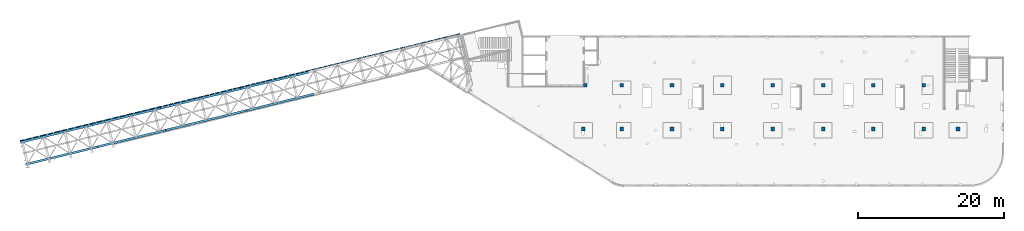
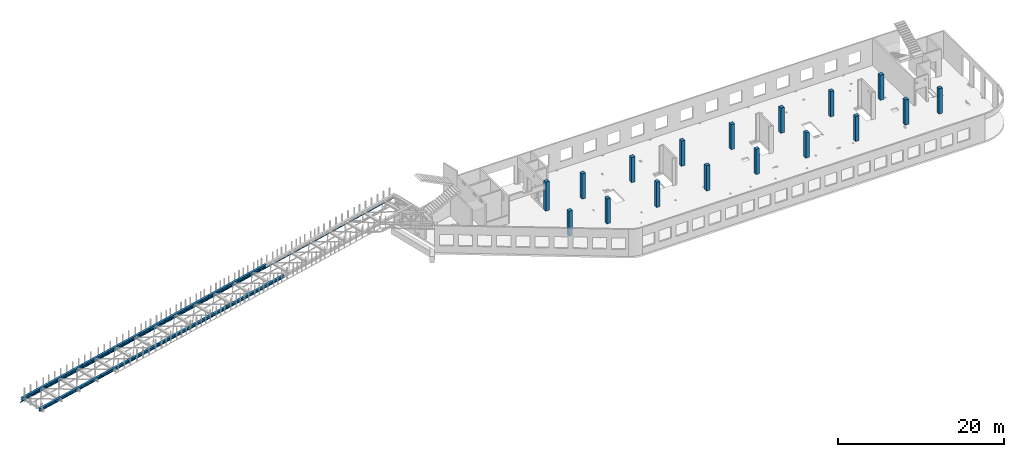
# One storey, part 12 of 66: 17 columns, 9 beams.
"""IFC4 building model written with IfcOpenShell, lengths in millimetres."""

from ifc_helpers import new_model, entity, si_unit, converted_unit, derived_unit, direction, frame, origin, place, context, subcontext, project, spatial, indexed_curve, outline, extrude, source, transform, mapped, material, type_object, type_shapes, element, save


model = new_model("IFC4")

# Units and contexts
model_context = context("Model", 3, precision=0.01, world=origin(), true_north=direction((6.12303176911189e-17, 1.0)))
plan_context = context("Plan", 3, precision=0.01, world=origin(), true_north=direction((6.12303176911189e-17, 1.0)))
body_context = subcontext(model_context, "Body", "Model", "MODEL_VIEW")
ifc_project = project(units=[si_unit("LENGTHUNIT", "METRE", prefix="MILLI"), si_unit("AREAUNIT", "SQUARE_METRE"), si_unit("VOLUMEUNIT", "CUBIC_METRE"), converted_unit("PLANEANGLEUNIT", "DEGREE", entity("IfcRatioMeasure", 0.0174532925199433), si_unit("PLANEANGLEUNIT", "RADIAN"), dimensions=[0, 0, 0, 0, 0, 0, 0]), si_unit("MASSUNIT", "GRAM", prefix="KILO"), derived_unit("MASSDENSITYUNIT", [(si_unit("MASSUNIT", "GRAM", prefix="KILO"), 1), (si_unit("LENGTHUNIT", "METRE"), -3)]), derived_unit("MOMENTOFINERTIAUNIT", [(si_unit("LENGTHUNIT", "METRE"), 4)]), si_unit("TIMEUNIT", "SECOND"), si_unit("FREQUENCYUNIT", "HERTZ"), si_unit("THERMODYNAMICTEMPERATUREUNIT", "DEGREE_CELSIUS"), derived_unit("THERMALTRANSMITTANCEUNIT", [(si_unit("MASSUNIT", "GRAM", prefix="KILO"), 1), (si_unit("THERMODYNAMICTEMPERATUREUNIT", "KELVIN"), -1), (si_unit("TIMEUNIT", "SECOND"), -3)]), derived_unit("VOLUMETRICFLOWRATEUNIT", [(si_unit("LENGTHUNIT", "METRE"), 3), (si_unit("TIMEUNIT", "SECOND"), -1)]), derived_unit("MASSFLOWRATEUNIT", [(si_unit("MASSUNIT", "GRAM", prefix="KILO"), 1), (si_unit("TIMEUNIT", "SECOND"), -1)]), derived_unit("ROTATIONALFREQUENCYUNIT", [(si_unit("TIMEUNIT", "SECOND"), -1)]), si_unit("ELECTRICCURRENTUNIT", "AMPERE"), si_unit("ELECTRICVOLTAGEUNIT", "VOLT"), si_unit("POWERUNIT", "WATT"), si_unit("FORCEUNIT", "NEWTON", prefix="KILO"), si_unit("ILLUMINANCEUNIT", "LUX"), si_unit("LUMINOUSFLUXUNIT", "LUMEN"), si_unit("LUMINOUSINTENSITYUNIT", "CANDELA"), derived_unit("USERDEFINED", [(si_unit("MASSUNIT", "GRAM", prefix="KILO"), -1), (si_unit("LENGTHUNIT", "METRE"), -2), (si_unit("TIMEUNIT", "SECOND"), 3), (si_unit("LUMINOUSFLUXUNIT", "LUMEN"), 1)]), derived_unit("LINEARVELOCITYUNIT", [(si_unit("LENGTHUNIT", "METRE"), 1), (si_unit("TIMEUNIT", "SECOND"), -1)]), si_unit("PRESSUREUNIT", "PASCAL"), derived_unit("USERDEFINED", [(si_unit("LENGTHUNIT", "METRE"), -2), (si_unit("MASSUNIT", "GRAM", prefix="KILO"), 1), (si_unit("TIMEUNIT", "SECOND"), -2)]), derived_unit("LINEARFORCEUNIT", [(si_unit("MASSUNIT", "GRAM", prefix="KILO"), 1), (si_unit("LENGTHUNIT", "METRE"), 1), (si_unit("TIMEUNIT", "SECOND"), -2), (si_unit("LENGTHUNIT", "METRE"), -1)]), derived_unit("PLANARFORCEUNIT", [(si_unit("MASSUNIT", "GRAM", prefix="KILO"), 1), (si_unit("LENGTHUNIT", "METRE"), 1), (si_unit("TIMEUNIT", "SECOND"), -2), (si_unit("LENGTHUNIT", "METRE"), -2)])], contexts=[model_context, plan_context])

# Site, building, storey
site_placement = place(None, origin())
site = spatial("IfcSite", under=ifc_project, at=site_placement, CompositionType="ELEMENT")
building_placement = place(site_placement, origin())
building = spatial("IfcBuilding", under=site, at=building_placement, CompositionType="ELEMENT")
storey_placement = place(building_placement, frame((0.0, 0.0, 19800.0)))
storey = spatial("IfcBuildingStorey", under=building, at=storey_placement, Name="06", CompositionType="ELEMENT", Elevation=19800.0)

# Columns
ifc_material_1 = material()
column_type_1 = type_object("IfcColumnType", PredefinedType="COLUMN", material=ifc_material_1)
shared_shape_1 = source(origin(), body_context, "Body", "SweptSolid", [
    extrude(outline(indexed_curve([(-249.999999999999, -249.999999999999), (250.000000000001, -249.999999999999), (250.000000000001, 249.999999999999), (-249.999999999999, 249.999999999999), (-249.999999999999, -249.999999999999)], self_intersect=False)), frame((15900.0, 7700.0, 19650.0), z_axis=(0.0, 0.0, 1.0), x_axis=(0.0, -1.0, 0.0)), (0.0, 0.0, 1.0), 3700.0),
])
type_shapes(column_type_1, [shared_shape_1])
placement_1 = place(storey_placement, frame((0.0, 0.0, -19800.0)))
element("IfcColumn", 1, at=placement_1, inside=storey, type_object=column_type_1, PredefinedType="COLUMN", context=body_context, shape_type="MappedRepresentation", body=[
    mapped(shared_shape_1, transform((0.0, 0.0, 0.0), scale=1.0)),
])
column_type_2 = type_object("IfcColumnType", PredefinedType="COLUMN", material=ifc_material_1)
shared_shape_2 = source(origin(), body_context, "Body", "SweptSolid", [
    extrude(outline(indexed_curve([(-249.999999999999, -249.999999999999), (250.000000000001, -249.999999999999), (250.000000000001, 249.999999999999), (-249.999999999999, 249.999999999999), (-249.999999999999, -249.999999999999)], self_intersect=False)), frame((21170.0, 7700.0, 19650.0), z_axis=(0.0, 0.0, 1.0), x_axis=(0.0, -1.0, 0.0)), (0.0, 0.0, 1.0), 3700.0),
])
type_shapes(column_type_2, [shared_shape_2])
element("IfcColumn", 2, at=placement_1, inside=storey, type_object=column_type_2, PredefinedType="COLUMN", context=body_context, shape_type="MappedRepresentation", body=[
    mapped(shared_shape_2, transform((0.0, 0.0, 0.0), scale=1.0)),
])
column_type_3 = type_object("IfcColumnType", PredefinedType="COLUMN", material=ifc_material_1)
shared_shape_3 = source(origin(), body_context, "Body", "SweptSolid", [
    extrude(outline(indexed_curve([(-249.999999999999, -249.999999999999), (250.000000000001, -249.999999999999), (249.999999999999, 249.999999999999), (-250.000000000001, 249.999999999999), (-249.999999999999, -249.999999999999)], self_intersect=False)), frame((28070.0, 7700.0, 19650.0), z_axis=(0.0, 0.0, 1.0), x_axis=(0.0, -1.0, 0.0)), (0.0, 0.0, 1.0), 3700.0),
])
type_shapes(column_type_3, [shared_shape_3])
element("IfcColumn", 3, at=placement_1, inside=storey, type_object=column_type_3, PredefinedType="COLUMN", context=body_context, shape_type="MappedRepresentation", body=[
    mapped(shared_shape_3, transform((0.0, 0.0, 0.0), scale=1.0)),
])
column_type_4 = type_object("IfcColumnType", PredefinedType="COLUMN", material=ifc_material_1)
shared_shape_4 = source(origin(), body_context, "Body", "SweptSolid", [
    extrude(outline(indexed_curve([(-249.999999999999, -250.000000000004), (250.000000000001, -250.000000000004), (250.000000000001, 249.999999999995), (-249.999999999999, 249.999999999995), (-249.999999999999, -250.000000000004)], self_intersect=False)), frame((34970.0, 7700.0, 19650.0), z_axis=(0.0, 0.0, 1.0), x_axis=(0.0, -1.0, 0.0)), (0.0, 0.0, 1.0), 3700.0),
])
type_shapes(column_type_4, [shared_shape_4])
element("IfcColumn", 4, at=placement_1, inside=storey, type_object=column_type_4, PredefinedType="COLUMN", context=body_context, shape_type="MappedRepresentation", body=[
    mapped(shared_shape_4, transform((0.0, 0.0, 0.0), scale=1.0)),
])
column_type_5 = type_object("IfcColumnType", PredefinedType="COLUMN", material=ifc_material_1)
shared_shape_5 = source(origin(), body_context, "Body", "SweptSolid", [
    extrude(outline(indexed_curve([(-249.999999999999, -250.000000000004), (250.000000000001, -250.000000000004), (249.999999999999, 249.999999999995), (-250.000000000001, 250.000000000004), (-249.999999999999, -250.000000000004)], self_intersect=False)), frame((41870.0, 7700.0, 19650.0), z_axis=(0.0, 0.0, 1.0), x_axis=(0.0, -1.0, 0.0)), (0.0, 0.0, 1.0), 3700.0),
])
type_shapes(column_type_5, [shared_shape_5])
element("IfcColumn", 5, at=placement_1, inside=storey, type_object=column_type_5, PredefinedType="COLUMN", context=body_context, shape_type="MappedRepresentation", body=[
    mapped(shared_shape_5, transform((0.0, 0.0, 0.0), scale=1.0)),
])
column_type_6 = type_object("IfcColumnType", PredefinedType="COLUMN", material=ifc_material_1)
shared_shape_6 = source(origin(), body_context, "Body", "SweptSolid", [
    extrude(outline(indexed_curve([(-249.999999999999, -250.000000000004), (250.000000000001, -250.000000000004), (250.000000000001, 249.999999999995), (-249.999999999999, 250.000000000004), (-249.999999999999, -250.000000000004)], self_intersect=False)), frame((48770.0, 7700.0, 19650.0), z_axis=(0.0, 0.0, 1.0), x_axis=(0.0, -1.0, 0.0)), (0.0, 0.0, 1.0), 3700.0),
])
type_shapes(column_type_6, [shared_shape_6])
element("IfcColumn", 6, at=placement_1, inside=storey, type_object=column_type_6, PredefinedType="COLUMN", context=body_context, shape_type="MappedRepresentation", body=[
    mapped(shared_shape_6, transform((0.0, 0.0, 0.0), scale=1.0)),
])
column_type_7 = type_object("IfcColumnType", PredefinedType="COLUMN", material=ifc_material_1)
shared_shape_7 = source(origin(), body_context, "Body", "SweptSolid", [
    extrude(outline(indexed_curve([(-249.999999999999, -250.000000000004), (250.000000000001, -250.000000000004), (249.999999999999, 249.999999999995), (-250.000000000001, 250.000000000004), (-249.999999999999, -250.000000000004)], self_intersect=False)), frame((55670.0, 7700.0, 19650.0), z_axis=(0.0, 0.0, 1.0), x_axis=(0.0, -1.0, 0.0)), (0.0, 0.0, 1.0), 3700.0),
])
type_shapes(column_type_7, [shared_shape_7])
element("IfcColumn", 7, at=placement_1, inside=storey, type_object=column_type_7, PredefinedType="COLUMN", context=body_context, shape_type="MappedRepresentation", body=[
    mapped(shared_shape_7, transform((0.0, 0.0, 0.0), scale=1.0)),
])
column_type_8 = type_object("IfcColumnType", PredefinedType="COLUMN", material=ifc_material_1)
shared_shape_8 = source(origin(), body_context, "Body", "SweptSolid", [
    extrude(outline(indexed_curve([(-249.999999999999, -250.000000000004), (250.000000000001, -250.000000000004), (250.000000000001, 249.999999999995), (-249.999999999999, 250.000000000004), (-249.999999999999, -250.000000000004)], self_intersect=False)), frame((62570.0, 7700.0, 19650.0), z_axis=(0.0, 0.0, 1.0), x_axis=(0.0, -1.0, 0.0)), (0.0, 0.0, 1.0), 3700.0),
])
type_shapes(column_type_8, [shared_shape_8])
element("IfcColumn", 8, at=placement_1, inside=storey, type_object=column_type_8, PredefinedType="COLUMN", context=body_context, shape_type="MappedRepresentation", body=[
    mapped(shared_shape_8, transform((0.0, 0.0, 0.0), scale=1.0)),
])
column_type_9 = type_object("IfcColumnType", PredefinedType="COLUMN", material=ifc_material_1)
shared_shape_9 = source(origin(), body_context, "Body", "SweptSolid", [
    extrude(outline(indexed_curve([(-249.999999999999, -250.000000000004), (250.000000000001, -250.000000000004), (250.000000000001, 249.999999999995), (-249.999999999999, 250.000000000004), (-249.999999999999, -250.000000000004)], self_intersect=False)), frame((67270.0, 7700.0, 19650.0), z_axis=(0.0, 0.0, 1.0), x_axis=(0.0, -1.0, 0.0)), (0.0, 0.0, 1.0), 3700.0),
])
type_shapes(column_type_9, [shared_shape_9])
element("IfcColumn", 9, at=placement_1, inside=storey, type_object=column_type_9, PredefinedType="COLUMN", context=body_context, shape_type="MappedRepresentation", body=[
    mapped(shared_shape_9, transform((0.0, 0.0, 0.0), scale=1.0)),
])
column_type_10 = type_object("IfcColumnType", PredefinedType="COLUMN", material=ifc_material_1)
shared_shape_10 = source(origin(), body_context, "Body", "SweptSolid", [
    extrude(outline(indexed_curve([(-249.999999999999, -249.999999999999), (249.999999999999, -249.999999999999), (249.999999999999, 249.999999999999), (-249.999999999999, 249.999999999999), (-249.999999999999, -249.999999999999)], self_intersect=False)), frame((21170.0, 13700.0, 19650.0), z_axis=(0.0, 0.0, 1.0), x_axis=(0.0, -1.0, 0.0)), (0.0, 0.0, 1.0), 3700.0),
])
type_shapes(column_type_10, [shared_shape_10])
element("IfcColumn", 10, at=placement_1, inside=storey, type_object=column_type_10, PredefinedType="COLUMN", context=body_context, shape_type="MappedRepresentation", body=[
    mapped(shared_shape_10, transform((0.0, 0.0, 0.0), scale=1.0)),
])
column_type_11 = type_object("IfcColumnType", PredefinedType="COLUMN", material=ifc_material_1)
shared_shape_11 = source(origin(), body_context, "Body", "SweptSolid", [
    extrude(outline(indexed_curve([(-249.999999999999, -249.999999999999), (249.999999999999, -249.999999999999), (249.999999999999, 249.999999999999), (-249.999999999999, 249.999999999999), (-249.999999999999, -249.999999999999)], self_intersect=False)), frame((28070.0, 13700.0, 19650.0), z_axis=(0.0, 0.0, 1.0), x_axis=(0.0, -1.0, 0.0)), (0.0, 0.0, 1.0), 3700.0),
])
type_shapes(column_type_11, [shared_shape_11])
element("IfcColumn", 11, at=placement_1, inside=storey, type_object=column_type_11, PredefinedType="COLUMN", context=body_context, shape_type="MappedRepresentation", body=[
    mapped(shared_shape_11, transform((0.0, 0.0, 0.0), scale=1.0)),
])
column_type_12 = type_object("IfcColumnType", PredefinedType="COLUMN", material=ifc_material_1)
shared_shape_12 = source(origin(), body_context, "Body", "SweptSolid", [
    extrude(outline(indexed_curve([(-249.999999999999, -249.999999999999), (249.999999999999, -249.999999999999), (249.999999999999, 249.999999999999), (-249.999999999999, 249.999999999999), (-249.999999999999, -249.999999999999)], self_intersect=False)), frame((34970.0, 13700.0, 19650.0), z_axis=(0.0, 0.0, 1.0), x_axis=(0.0, -1.0, 0.0)), (0.0, 0.0, 1.0), 3700.0),
])
type_shapes(column_type_12, [shared_shape_12])
element("IfcColumn", 12, at=placement_1, inside=storey, type_object=column_type_12, PredefinedType="COLUMN", context=body_context, shape_type="MappedRepresentation", body=[
    mapped(shared_shape_12, transform((0.0, 0.0, 0.0), scale=1.0)),
])
column_type_13 = type_object("IfcColumnType", PredefinedType="COLUMN", material=ifc_material_1)
shared_shape_13 = source(origin(), body_context, "Body", "SweptSolid", [
    extrude(outline(indexed_curve([(-249.999999999999, -250.000000000004), (249.999999999999, -250.000000000004), (249.999999999999, 249.999999999995), (-249.999999999999, 250.000000000004), (-249.999999999999, -250.000000000004)], self_intersect=False)), frame((41870.0, 13700.0, 19650.0), z_axis=(0.0, 0.0, 1.0), x_axis=(0.0, -1.0, 0.0)), (0.0, 0.0, 1.0), 3700.0),
])
type_shapes(column_type_13, [shared_shape_13])
element("IfcColumn", 13, at=placement_1, inside=storey, type_object=column_type_13, PredefinedType="COLUMN", context=body_context, shape_type="MappedRepresentation", body=[
    mapped(shared_shape_13, transform((0.0, 0.0, 0.0), scale=1.0)),
])
column_type_14 = type_object("IfcColumnType", PredefinedType="COLUMN", material=ifc_material_1)
shared_shape_14 = source(origin(), body_context, "Body", "SweptSolid", [
    extrude(outline(indexed_curve([(-249.999999999999, -250.000000000004), (249.999999999999, -250.000000000004), (249.999999999999, 249.999999999995), (-249.999999999999, 250.000000000004), (-249.999999999999, -250.000000000004)], self_intersect=False)), frame((48770.0, 13700.0, 19650.0), z_axis=(0.0, 0.0, 1.0), x_axis=(0.0, -1.0, 0.0)), (0.0, 0.0, 1.0), 3700.0),
])
type_shapes(column_type_14, [shared_shape_14])
element("IfcColumn", 14, at=placement_1, inside=storey, type_object=column_type_14, PredefinedType="COLUMN", context=body_context, shape_type="MappedRepresentation", body=[
    mapped(shared_shape_14, transform((0.0, 0.0, 0.0), scale=1.0)),
])
column_type_15 = type_object("IfcColumnType", PredefinedType="COLUMN", material=ifc_material_1)
shared_shape_15 = source(origin(), body_context, "Body", "SweptSolid", [
    extrude(outline(indexed_curve([(-249.999999999999, -249.999999999995), (249.999999999999, -249.999999999995), (249.999999999999, 250.000000000004), (-249.999999999999, 250.000000000012), (-249.999999999999, -249.999999999995)], self_intersect=False)), frame((55670.0, 13700.0, 19650.0), z_axis=(0.0, 0.0, 1.0), x_axis=(0.0, -1.0, 0.0)), (0.0, 0.0, 1.0), 3700.0),
])
type_shapes(column_type_15, [shared_shape_15])
element("IfcColumn", 15, at=placement_1, inside=storey, type_object=column_type_15, PredefinedType="COLUMN", context=body_context, shape_type="MappedRepresentation", body=[
    mapped(shared_shape_15, transform((0.0, 0.0, 0.0), scale=1.0)),
])
column_type_16 = type_object("IfcColumnType", PredefinedType="COLUMN", material=ifc_material_1)
shared_shape_16 = source(origin(), body_context, "Body", "SweptSolid", [
    extrude(outline(indexed_curve([(-249.999999999999, -250.000000000004), (249.999999999999, -250.000000000004), (249.999999999999, 249.999999999995), (-249.999999999999, 250.000000000004), (-249.999999999999, -250.000000000004)], self_intersect=False)), frame((62570.0, 13700.0, 19650.0), z_axis=(0.0, 0.0, 1.0), x_axis=(0.0, -1.0, 0.0)), (0.0, 0.0, 1.0), 3700.0),
])
type_shapes(column_type_16, [shared_shape_16])
element("IfcColumn", 16, at=placement_1, inside=storey, type_object=column_type_16, PredefinedType="COLUMN", context=body_context, shape_type="MappedRepresentation", body=[
    mapped(shared_shape_16, transform((0.0, 0.0, 0.0), scale=1.0)),
])
column_type_17 = type_object("IfcColumnType", PredefinedType="COLUMN", material=ifc_material_1)
shared_shape_17 = source(origin(), body_context, "Body", "SweptSolid", [
    extrude(outline(indexed_curve([(-249.999999999999, -249.999999999999), (249.999999999999, -249.999999999999), (249.999999999999, 249.999999999999), (-249.999999999999, 249.999999999999), (-249.999999999999, -249.999999999999)], self_intersect=False)), frame((16150.0, 13700.0, 19650.0), z_axis=(0.0, 0.0, 1.0), x_axis=(0.0, -1.0, 0.0)), (0.0, 0.0, 1.0), 4250.0),
])
type_shapes(column_type_17, [shared_shape_17])
element("IfcColumn", 17, at=placement_1, inside=storey, type_object=column_type_17, PredefinedType="COLUMN", context=body_context, shape_type="MappedRepresentation", body=[
    mapped(shared_shape_17, transform((0.0, 0.0, 0.0), scale=1.0)),
])

# Beams
ifc_material_2 = material(Name="Metal painted (White)")
beam_type = type_object("IfcBeamType", PredefinedType="BEAM")
placement_2 = place(storey_placement, origin())
element("IfcBeam", 18, at=placement_2, inside=storey, type_object=beam_type, material=ifc_material_2, ObjectType="Steel Beam", PredefinedType="BEAM", context=body_context, shape_type="SweptSolid", body=[
    extrude(outline(indexed_curve([(-195.999999999999, -150.000000000005), (-180.000000000002, -150.000000000005), (-180.000000000002, -27.7500000000041), (-178.325349715245, -19.3309644879713), (-173.556349186105, -12.1936508138996), (-166.419035512031, -7.42465028475701), (-157.999999999999, -5.75000000000425), (158.000000000003, -5.75000000000425), (166.419035512027, -7.42465028475701), (173.556349186101, -12.1936508138996), (178.325349715249, -19.3309644879713), (180.000000000002, -27.7500000000041), (180.000000000002, -150.000000000005), (195.999999999999, -150.000000000005), (195.999999999999, 149.999999999996), (180.000000000002, 149.999999999996), (180.000000000002, 27.7499999999947), (178.325349715249, 19.3309644879649), (173.556349186101, 12.1936508138912), (166.419035512027, 7.42465028474757), (158.000000000003, 5.74999999999584), (-157.999999999999, 5.74999999999373), (-166.419035512031, 7.42465028474757), (-173.556349186105, 12.1936508138891), (-178.325349715245, 19.3309644879649), (-179.999999999998, 27.7499999999947), (-180.000000000002, 149.999999999992), (-195.999999999999, 149.999999999996), (-195.999999999999, -150.000000000005)], self_intersect=False)), frame((-30278.97, 10220.76, 3912.0), z_axis=(0.971552058141469, 0.236826092990355, 0.0), x_axis=(0.0, 0.0, 1.0)), (0.0, 0.0, 1.0), 9480.00000000004),
])
element("IfcBeam", 19, at=placement_2, inside=storey, type_object=beam_type, material=ifc_material_2, ObjectType="Steel Beam", PredefinedType="BEAM", context=body_context, shape_type="SweptSolid", body=[
    extrude(outline(indexed_curve([(-195.999999999999, -149.999999999998), (-180.000000000002, -149.999999999998), (-180.000000000002, -27.7499999999968), (-178.325349715245, -19.3309644879691), (-173.556349186105, -12.1936508138933), (-166.419035512031, -7.42465028474757), (-157.999999999999, -5.74999999999794), (158.000000000003, -5.74999999999794), (166.419035512027, -7.42465028474757), (173.556349186101, -12.1936508138933), (178.325349715249, -19.3309644879691), (180.000000000002, -27.7499999999968), (180.000000000002, -149.999999999998), (195.999999999999, -149.999999999998), (195.999999999999, 150.000000000001), (180.000000000002, 150.000000000001), (180.000000000002, 27.7499999999999), (178.325349715249, 19.3309644879691), (173.556349186101, 12.1936508138954), (166.419035512027, 7.42465028475491), (158.000000000003, 5.75000000000005), (-157.999999999999, 5.74999999999794), (-166.419035512031, 7.4246502847528), (-173.556349186105, 12.1936508138933), (-178.325349715245, 19.3309644879713), (-179.999999999998, 27.750000000002), (-180.000000000002, 149.999999999998), (-195.999999999999, 150.000000000001), (-195.999999999999, -149.999999999998)], self_intersect=False)), frame((-31013.13, 13232.57, 3912.0), z_axis=(0.971552058141469, 0.236826092990355, 0.0), x_axis=(0.0, 0.0, 1.0)), (0.0, 0.0, 1.0), 9480.00000000004),
])
element("IfcBeam", 20, at=placement_2, inside=storey, type_object=beam_type, material=ifc_material_2, ObjectType="Steel Beam", PredefinedType="BEAM", context=body_context, shape_type="SweptSolid", body=[
    extrude(outline(indexed_curve([(-196.000000000027, -149.999999999965), (-180.000000000027, -149.999999999965), (-180.000000000003, -27.7499999999655), (-178.325349715249, -19.330964487933), (-173.556349186107, -12.1936508138612), (-166.419035512033, -7.42465028472002), (-158.0, -5.74999999997102), (158.000000000002, -5.75000000003117), (166.419035512025, -7.42465028478559), (173.556349186098, -12.1936508139296), (178.325349715246, -19.3309644880032), (179.999999999997, -27.7500000000364), (179.999999999974, -150.000000000036), (195.99999999997, -150.000000000039), (196.000000000027, 149.99999999996), (180.000000000031, 149.999999999964), (180.000000000008, 27.7499999999645), (178.325349715253, 19.3309644879319), (173.556349186103, 12.1936508138612), (166.419035512028, 7.42465028471897), (158.000000000004, 5.74999999996787), (-157.999999999998, 5.75000000002802), (-166.41903551203, 7.42465028478138), (-173.556349186103, 12.1936508139265), (-178.325349715241, 19.330964487999), (-179.999999999997, 27.7500000000333), (-179.999999999974, 150.000000000032), (-195.99999999997, 150.000000000035), (-196.000000000027, -149.999999999965)], self_intersect=False)), frame((-41354.67, 7520.94, 3912.0), z_axis=(0.971552058141476, 0.236826092990324, 0.0), x_axis=(0.0, 0.0, 1.0)), (0.0, 0.0, 1.0), 11400.0),
])
element("IfcBeam", 21, at=placement_2, inside=storey, type_object=beam_type, material=ifc_material_2, ObjectType="Steel Beam", PredefinedType="BEAM", context=body_context, shape_type="SweptSolid", body=[
    extrude(outline(indexed_curve([(-195.999999999989, -150.000000000008), (-179.999999999988, -150.000000000008), (-179.999999999996, -27.7500000000065), (-178.325349715244, -19.3309644879714), (-173.556349186104, -12.1936508138995), (-166.419035512031, -7.42465028475638), (-157.999999999998, -5.75000000000412), (158.000000000003, -5.7499999999844), (166.419035512027, -7.42465028473455), (173.556349186101, -12.1936508138798), (178.325349715251, -19.3309644879501), (180.000000000004, -27.7499999999818), (180.000000000012, -149.999999999982), (196.000000000009, -149.999999999981), (195.999999999989, 150.000000000017), (179.999999999993, 150.000000000016), (180.000000000001, 27.750000000017), (178.325349715248, 19.330964487984), (173.5563491861, 12.1936508139141), (166.419035512026, 7.4246502847669), (158.000000000003, 5.75000000001669), (-157.999999999999, 5.74999999999492), (-166.419035512032, 7.42465028474712), (-173.556349186106, 12.1936508138903), (-178.325349715246, 19.3309644879596), (-180.000000000004, 27.7499999999944), (-180.000000000012, 149.999999999995), (-196.000000000009, 149.999999999993), (-195.999999999989, -150.000000000008)], self_intersect=False)), frame((-50681.57, 5247.41, 3912.0), z_axis=(0.97155205814146, 0.236826092990391, 0.0), x_axis=(0.0, 0.0, 1.0)), (0.0, 0.0, 1.0), 9599.99999999999),
])
element("IfcBeam", 22, at=placement_2, inside=storey, type_object=beam_type, material=ifc_material_2, ObjectType="Steel Beam", PredefinedType="BEAM", context=body_context, shape_type="SweptSolid", body=[
    extrude(outline(indexed_curve([(-195.99999999998, -150.000000000028), (-179.999999999979, -150.000000000028), (-179.999999999995, -27.7500000000278), (-178.325349715242, -19.330964487992), (-173.556349186103, -12.1936508139219), (-166.41903551203, -7.42465028477677), (-157.999999999998, -5.75000000002393), (158.000000000004, -5.749999999984), (166.419035512028, -7.42465028473567), (173.556349186102, -12.1936508138784), (178.325349715252, -19.3309644879484), (180.000000000006, -27.749999999982), (180.000000000022, -149.999999999982), (196.000000000018, -149.99999999998), (195.99999999998, 150.000000000021), (179.999999999983, 150.000000000019), (179.999999999999, 27.7500000000194), (178.325349715247, 19.3309644879868), (173.556349186099, 12.1936508139145), (166.419035512026, 7.42465028476941), (158.000000000002, 5.75000000001657), (-157.999999999999, 5.74999999997511), (-166.419035512032, 7.42465028472726), (-173.556349186106, 12.1936508138689), (-178.325349715247, 19.330964487941), (-180.000000000006, 27.7499999999726), (-180.000000000022, 149.999999999972), (-196.000000000018, 149.99999999997), (-195.99999999998, -150.000000000028)], self_intersect=False)), frame((-60542.82, 2843.62, 3912.0), z_axis=(0.97155205814146, 0.236826092990392, 0.0), x_axis=(0.0, 0.0, 1.0)), (0.0, 0.0, 1.0), 10150.0),
])
element("IfcBeam", 23, at=placement_2, inside=storey, type_object=beam_type, material=ifc_material_2, ObjectType="Steel Beam", PredefinedType="BEAM", context=body_context, shape_type="SweptSolid", body=[
    extrude(outline(indexed_curve([(-196.000000000018, -149.999999999979), (-180.000000000017, -149.999999999979), (-180.000000000002, -27.7499999999784), (-178.325349715247, -19.3309644879447), (-173.556349186106, -12.1936508138726), (-166.419035512032, -7.42465028473094), (-157.999999999999, -5.74999999998347), (158.000000000002, -5.75000000002288), (166.419035512026, -7.42465028477467), (173.556349186099, -12.1936508139203), (178.325349715247, -19.3309644879936), (179.999999999999, -27.7500000000236), (179.999999999983, -150.000000000024), (195.99999999998, -150.000000000026), (196.000000000018, 149.999999999972), (180.000000000022, 149.999999999974), (180.000000000006, 27.7499999999742), (178.325349715252, 19.3309644879405), (173.556349186102, 12.1936508138705), (166.419035512028, 7.42465028473094), (158.000000000004, 5.74999999997721), (-157.999999999998, 5.75000000001867), (-166.41903551203, 7.42465028477256), (-173.556349186103, 12.1936508139161), (-178.325349715242, 19.3309644879873), (-179.999999999999, 27.7500000000194), (-179.999999999983, 150.000000000022), (-195.99999999998, 150.000000000022), (-196.000000000018, -149.999999999979)], self_intersect=False)), frame((-42088.83, 10532.75, 3912.0), z_axis=(0.97155205814146, 0.236826092990393, 0.0), x_axis=(0.0, 0.0, 1.0)), (0.0, 0.0, 1.0), 11400.0),
])
element("IfcBeam", 24, at=placement_2, inside=storey, type_object=beam_type, material=ifc_material_2, ObjectType="Steel Beam", PredefinedType="BEAM", context=body_context, shape_type="SweptSolid", body=[
    extrude(outline(indexed_curve([(-195.999999999999, -150.000000000009), (-179.999999999998, -150.000000000009), (-179.999999999998, -27.7500000000104), (-178.325349715245, -19.3309644879765), (-173.556349186105, -12.1936508139038), (-166.419035512031, -7.42465028475806), (-157.999999999999, -5.75000000000741), (158.000000000003, -5.75000000000741), (166.419035512027, -7.42465028476017), (173.556349186101, -12.1936508139038), (178.325349715249, -19.3309644879765), (180.000000000002, -27.7500000000094), (180.000000000002, -150.000000000009), (195.999999999999, -150.000000000009), (195.999999999999, 149.999999999993), (180.000000000002, 149.999999999993), (180.000000000002, 27.7499999999905), (178.325349715249, 19.3309644879587), (173.556349186101, 12.193650813887), (166.419035512027, 7.42465028474544), (158.000000000003, 5.74999999999163), (-157.999999999999, 5.74999999999163), (-166.419035512031, 7.42465028474544), (-173.556349186105, 12.193650813887), (-178.325349715245, 19.3309644879587), (-180.000000000002, 27.7499999999905), (-180.000000000002, 149.999999999993), (-195.999999999999, 149.999999999993), (-195.999999999999, -150.000000000009)], self_intersect=False)), frame((-51415.73, 8259.22, 3912.0), z_axis=(0.971552058141476, 0.236826092990326, 0.0), x_axis=(0.0, 0.0, 1.0)), (0.0, 0.0, 1.0), 9599.99999999999),
])
element("IfcBeam", 25, at=placement_2, inside=storey, type_object=beam_type, material=ifc_material_2, ObjectType="Steel Beam", PredefinedType="BEAM", context=body_context, shape_type="SweptSolid", body=[
    extrude(outline(indexed_curve([(-196.000000000009, -149.999999999987), (-180.000000000008, -149.999999999987), (-180.0, -27.7499999999902), (-178.325349715246, -19.3309644879564), (-173.556349186106, -12.1936508138882), (-166.419035512032, -7.42465028473981), (-157.999999999999, -5.74999999999071), (158.000000000003, -5.75000000001043), (166.419035512026, -7.42465028476375), (173.5563491861, -12.1936508139079), (178.325349715248, -19.3309644879809), (180.000000000001, -27.7500000000138), (179.999999999993, -150.000000000013), (195.999999999989, -150.000000000014), (196.000000000009, 149.999999999985), (180.000000000012, 149.999999999986), (180.000000000004, 27.749999999986), (178.325349715251, 19.3309644879543), (173.556349186101, 12.193650813884), (166.419035512027, 7.42465028473981), (158.000000000003, 5.7499999999886), (-157.999999999998, 5.75000000000833), (-166.419035512031, 7.4246502847627), (-173.556349186104, 12.1936508139047), (-178.325349715244, 19.3309644879787), (-180.000000000001, 27.7500000000107), (-179.999999999993, 150.000000000011), (-195.999999999989, 150.000000000012), (-196.000000000009, -149.999999999987)], self_intersect=False)), frame((-61257.55, 5860.17, 3912.0), z_axis=(0.971552058141475, 0.236826092990328, 0.0), x_axis=(0.0, 0.0, 1.0)), (0.0, 0.0, 1.0), 10130.0),
])
element("IfcBeam", 26, at=placement_2, inside=storey, type_object=beam_type, material=ifc_material_2, ObjectType="Steel Beam", PredefinedType="BEAM", context=body_context, shape_type="SweptSolid", body=[
    extrude(outline(indexed_curve([(29.4768951153348, -56.8428769007988), (33.3787015556583, -56.8428769007988), (36.9835006656936, -55.3497202197882), (39.7424944585234, -52.5907264269536), (41.2356511395299, -48.9859273169197), (56.8428769008044, 29.476895115341), (56.842876900802, 33.3787015556629), (55.3497202197979, 36.9835006656927), (52.5907264269665, 39.7424944585207), (48.9859273169302, 41.235651139531), (-29.47689511533, 56.8428769008066), (-33.3787015556544, 56.8428769008024), (-36.9835006656878, 55.3497202197958), (-39.7424944585149, 52.5907264269696), (-41.2356511395204, 48.9859273169354), (-56.8428769007969, -29.4768951153249), (-56.8428769007966, -33.3787015556464), (-55.3497202197901, -36.9835006656854), (-52.5907264269636, -39.7424944585169), (-48.9859273169255, -41.2356511395232), (29.4768951153348, -56.8428769007988)], self_intersect=False), holes=[indexed_curve([(-50.9634988887027, -25.548420323389), (-37.3071763475843, 43.1065493048406), (-35.8140196665748, 46.711348414874), (-33.0550258737527, 49.4703422077012), (-29.4502267637152, 50.963498888707), (-25.5484203233911, 50.9634988887157), (43.1065493048342, 37.3071763475912), (46.7113484148714, 35.8140196665851), (49.4703422077006, 33.0550258737575), (50.9634988887068, 29.4502267637273), (50.9634988887072, 25.5484203234058), (37.3071763475929, -43.1065493048247), (35.8140196665894, -46.7113484148592), (33.0550258737553, -49.4703422076885), (29.4502267637231, -50.9634988886997), (25.5484203234005, -50.9634988886955), (-43.1065493048265, -37.3071763475795), (-46.7113484148645, -35.8140196665776), (-49.4703422076928, -33.0550258737502), (-50.9634988887034, -29.4502267637103), (-50.9634988887027, -25.548420323389)], self_intersect=False)]), frame((-61300.06, 6055.67, 3328.0), z_axis=(0.971552058141243, 0.236826092991282, 0.0), x_axis=(0.232275546020893, -0.95288395777052, -0.195090322015947)), (0.0, 0.0, 1.0), 62010.0),
])

save(model, "model.ifc")
